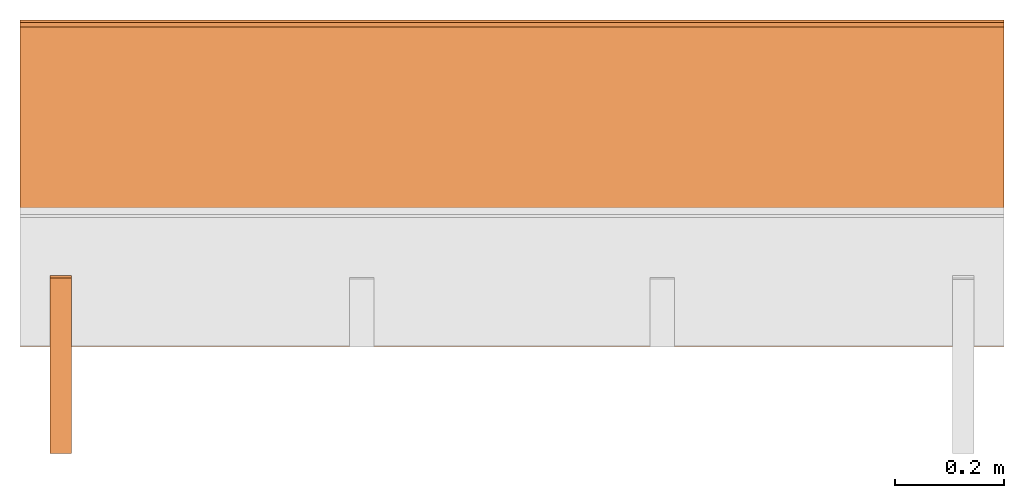
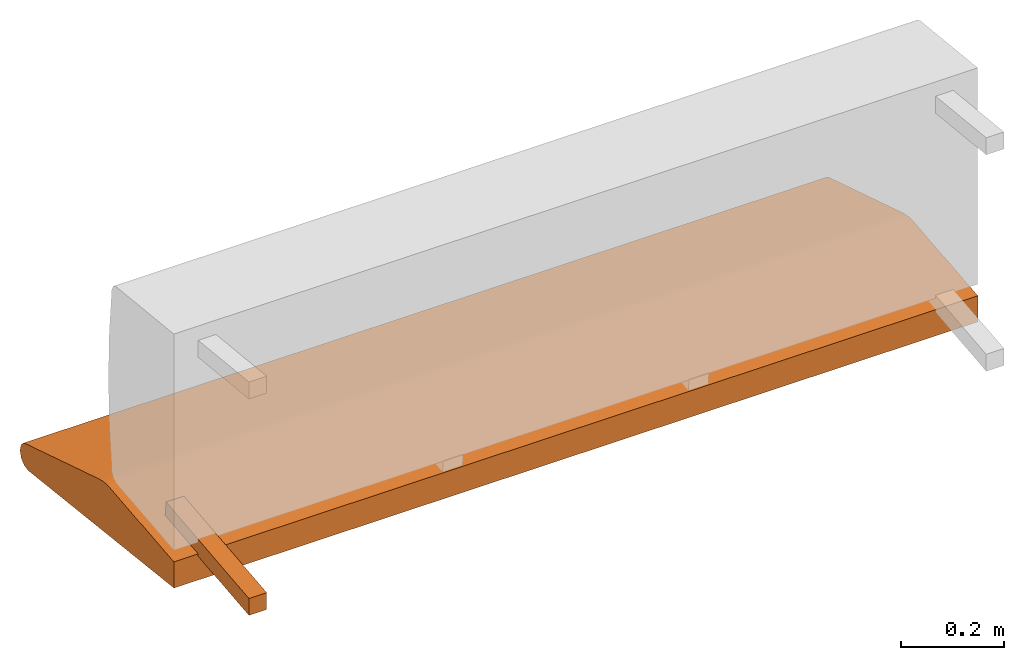
# One storey, part 2 of 3: 2 proxies, 1 element without a shape of its own.
"""IFC2X3 building model written with IfcOpenShell, lengths in metres."""

from ifc_helpers import new_model, si_unit, direction, origin_with_axes, place, context, project, spatial, faceted_brep, source, transform, mapped, element, aggregate, save


model = new_model("IFC2X3")

# Units and contexts
model_context = context("Model", 3, precision=1e-06, world=origin_with_axes(), true_north=direction((0.0, 1.0, 0.0)))
ifc_project = project(units=[si_unit("LENGTHUNIT", "METRE"), si_unit("AREAUNIT", "SQUARE_METRE"), si_unit("VOLUMEUNIT", "CUBIC_METRE")], contexts=[model_context])

# Site, building, storey
site_placement = place(None, origin_with_axes())
site = spatial("IfcSite", under=ifc_project, at=site_placement, CompositionType="ELEMENT")
building_placement = place(site_placement, origin_with_axes())
building = spatial("IfcBuilding", under=site, at=building_placement, Name="Default Building", CompositionType="ELEMENT")
storey_placement = place(building_placement, origin_with_axes())
storey = spatial("IfcBuildingStorey", under=building, at=storey_placement, Name="Default Storey", CompositionType="ELEMENT", Elevation=0.0)

# Assembly, proxies
assembly_placement = place(storey_placement, origin_with_axes())
assembly = element("IfcElementAssembly", 1, at=assembly_placement, inside=storey, AssemblyPlace="NOTDEFINED", PredefinedType="NOTDEFINED")
shared_shape_1 = source(origin_with_axes(), model_context, "Body", "Brep", [
    faceted_brep([(-0.8100000023841858, -0.3086628317832947, -0.31151315569877625), (-0.8100000023841858, -0.3086628317832947, -0.2712928354740143), (-0.8500000238418579, -0.3086628317832947, -0.31151315569877625), (-0.8500000238418579, -0.3086628317832947, -0.31151315569877625), (-0.8100000023841858, -0.3086628317832947, -0.2712928354740143), (-0.8500000238418579, -0.3086628317832947, -0.2712928354740143), (-0.8100000023841858, -0.3086628317832947, -0.2712928354740143), (-0.8100000023841858, 0.014455263502895832, -0.23733174800872803), (-0.8500000238418579, -0.3086628317832947, -0.2712928354740143), (-0.8500000238418579, -0.3086628317832947, -0.2712928354740143), (-0.8100000023841858, 0.014455263502895832, -0.23733174800872803), (-0.8500000238418579, 0.014455263502895832, -0.23733174800872803), (-0.8100000023841858, 0.014455263502895832, -0.23733174800872803), (-0.8100000023841858, 0.018636401742696762, -0.2771126329898834), (-0.8500000238418579, 0.014455263502895832, -0.23733174800872803), (-0.8500000238418579, 0.014455263502895832, -0.23733174800872803), (-0.8100000023841858, 0.018636401742696762, -0.2771126329898834), (-0.8500000238418579, 0.018636401742696762, -0.2771126329898834), (-0.8100000023841858, 0.018636401742696762, -0.2771126329898834), (-0.8100000023841858, -0.3086628317832947, -0.31151315569877625), (-0.8500000238418579, 0.018636401742696762, -0.2771126329898834), (-0.8500000238418579, 0.018636401742696762, -0.2771126329898834), (-0.8100000023841858, -0.3086628317832947, -0.31151315569877625), (-0.8500000238418579, -0.3086628317832947, -0.31151315569877625), (-0.8100000023841858, 0.018636401742696762, -0.2771126329898834), (-0.8100000023841858, 0.014455263502895832, -0.23733174800872803), (-0.8100000023841858, -0.3086628317832947, -0.31151315569877625), (-0.8100000023841858, -0.3086628317832947, -0.31151315569877625), (-0.8100000023841858, 0.014455263502895832, -0.23733174800872803), (-0.8100000023841858, -0.3086628317832947, -0.2712928354740143), (-0.8500000238418579, 0.014455263502895832, -0.23733174800872803), (-0.8500000238418579, 0.018636401742696762, -0.2771126329898834), (-0.8500000238418579, -0.3086628317832947, -0.2712928354740143), (-0.8500000238418579, -0.3086628317832947, -0.2712928354740143), (-0.8500000238418579, 0.018636401742696762, -0.2771126329898834), (-0.8500000238418579, -0.3086628317832947, -0.31151315569877625)], [[[0, 1, 2]], [[3, 4, 5]], [[6, 7, 8]], [[9, 10, 11]], [[12, 13, 14]], [[15, 16, 17]], [[18, 19, 20]], [[21, 22, 23]], [[24, 25, 26]], [[27, 28, 29]], [[30, 31, 32]], [[33, 34, 35]]]),
])
proxy_1_placement = place(assembly_placement, origin_with_axes())
proxy_1 = element("IfcBuildingElementProxy", 2, at=proxy_1_placement, Name="2", ObjectType="2", CompositionType="ELEMENT", context=model_context, shape_type="MappedRepresentation", body=[
    mapped(shared_shape_1, transform((0.0, 0.0, 0.0), scale=1.0)),
])
shared_shape_2 = source(origin_with_axes(), model_context, "Body", "Brep", [
    faceted_brep([(-0.9049999713897705, 0.14882974326610565, -0.2589503824710846), (-0.9049999713897705, 0.1383768916130066, -0.2594982087612152), (0.9049999713897705, 0.14882974326610565, -0.2589503824710846), (0.9049999713897705, 0.14882974326610565, -0.2589503824710846), (-0.9049999713897705, 0.1383768916130066, -0.2594982087612152), (0.9049999713897705, 0.1383768916130066, -0.2594982087612152), (0.9049999713897705, 0.01817154325544834, -0.2721322774887085), (0.9049999713897705, 0.1383768916130066, -0.2594982087612152), (-0.9049999713897705, 0.01817154325544834, -0.2721322774887085), (-0.9049999713897705, 0.01817154325544834, -0.2721322774887085), (0.9049999713897705, 0.1383768916130066, -0.2594982087612152), (-0.9049999713897705, 0.1383768916130066, -0.2594982087612152), (0.9049999713897705, 0.17872387170791626, -0.2635232210159302), (-0.9049999713897705, 0.17872387170791626, -0.2635232210159302), (-0.9049999713897705, 0.16395066678524017, -0.26010021567344666), (0.9049999713897705, 0.17872387170791626, -0.2635232210159302), (-0.9049999713897705, 0.16395066678524017, -0.26010021567344666), (0.9049999713897705, 0.16395066678524017, -0.26010021567344666), (0.9049999713897705, 0.16395066678524017, -0.26010021567344666), (-0.9049999713897705, 0.16395066678524017, -0.26010021567344666), (-0.9049999713897705, 0.14882974326610565, -0.2589503824710846), (0.9049999713897705, 0.16395066678524017, -0.26010021567344666), (-0.9049999713897705, 0.14882974326610565, -0.2589503824710846), (0.9049999713897705, 0.14882974326610565, -0.2589503824710846), (0.9049999713897705, 0.17872387170791626, -0.2635232210159302), (0.9049999713897705, 0.4682733118534088, -0.3542293608188629), (-0.9049999713897705, 0.17872387170791626, -0.2635232210159302), (-0.9049999713897705, 0.17872387170791626, -0.2635232210159302), (0.9049999713897705, 0.4682733118534088, -0.3542293608188629), (-0.9049999713897705, 0.4682733118534088, -0.3542293608188629), (0.9049999713897705, 0.4682733118534088, -0.3542293608188629), (0.9049999713897705, 0.4762941300868988, -0.35816407203674316), (-0.9049999713897705, 0.4682733118534088, -0.3542293608188629), (-0.9049999713897705, 0.4682733118534088, -0.3542293608188629), (0.9049999713897705, 0.4762941300868988, -0.35816407203674316), (-0.9049999713897705, 0.4762941300868988, -0.35816407203674316), (0.9049999713897705, 0.4762941300868988, -0.35816407203674316), (0.9049999713897705, 0.4814260005950928, -0.36358925700187683), (-0.9049999713897705, 0.4762941300868988, -0.35816407203674316), (-0.9049999713897705, 0.4762941300868988, -0.35816407203674316), (0.9049999713897705, 0.4814260005950928, -0.36358925700187683), (-0.9049999713897705, 0.4814260005950928, -0.36358925700187683), (0.9049999713897705, 0.4814260005950928, -0.36358925700187683), (0.9049999713897705, 0.4845067262649536, -0.3668460547924042), (-0.9049999713897705, 0.4814260005950928, -0.36358925700187683), (-0.9049999713897705, 0.4814260005950928, -0.36358925700187683), (0.9049999713897705, 0.4845067262649536, -0.3668460547924042), (-0.9049999713897705, 0.4845067262649536, -0.3668460547924042), (0.9049999713897705, 0.4845067262649536, -0.3668460547924042), (0.9049999713897705, 0.48888999223709106, -0.3822925090789795), (-0.9049999713897705, 0.4845067262649536, -0.3668460547924042), (-0.9049999713897705, 0.4845067262649536, -0.3668460547924042), (0.9049999713897705, 0.48888999223709106, -0.3822925090789795), (-0.9049999713897705, 0.48888999223709106, -0.3822925090789795), (0.9049999713897705, 0.48888999223709106, -0.3822925090789795), (0.9049999713897705, 0.4845067262649536, -0.3977389633655548), (-0.9049999713897705, 0.48888999223709106, -0.3822925090789795), (-0.9049999713897705, 0.48888999223709106, -0.3822925090789795), (0.9049999713897705, 0.4845067262649536, -0.3977389633655548), (-0.9049999713897705, 0.4845067262649536, -0.3977389633655548), (0.9049999713897705, 0.4845067262649536, -0.3977389633655548), (0.9049999713897705, 0.4726635813713074, -0.40858080983161926), (-0.9049999713897705, 0.4845067262649536, -0.3977389633655548), (-0.9049999713897705, 0.4845067262649536, -0.3977389633655548), (0.9049999713897705, 0.4726635813713074, -0.40858080983161926), (-0.9049999713897705, 0.4726635813713074, -0.40858080983161926), (0.9049999713897705, 0.4726635813713074, -0.40858080983161926), (0.9049999713897705, 0.4568909704685211, -0.41158604621887207), (-0.9049999713897705, 0.4726635813713074, -0.40858080983161926), (-0.9049999713897705, 0.4726635813713074, -0.40858080983161926), (0.9049999713897705, 0.4568909704685211, -0.41158604621887207), (-0.9049999713897705, 0.4568909704685211, -0.41158604621887207), (0.9049999713897705, 0.4568909704685211, -0.41158604621887207), (0.9049999713897705, 0.4574563503265381, -0.4066162109375), (-0.9049999713897705, 0.4568909704685211, -0.41158604621887207), (-0.9049999713897705, 0.4568909704685211, -0.41158604621887207), (0.9049999713897705, 0.4574563503265381, -0.4066162109375), (-0.9049999713897705, 0.4574563503265381, -0.4066162109375), (0.9049999713897705, 0.4574563503265381, -0.4066162109375), (0.9049999713897705, 0.45688581466674805, -0.41162365674972534), (-0.9049999713897705, 0.4574563503265381, -0.4066162109375), (-0.9049999713897705, 0.4574563503265381, -0.4066162109375), (0.9049999713897705, 0.45688581466674805, -0.41162365674972534), (-0.9049999713897705, 0.45688581466674805, -0.41162365674972534), (0.9049999713897705, 0.45688581466674805, -0.41162365674972534), (0.9049999713897705, -0.11158759891986847, -0.3467162549495697), (-0.9049999713897705, 0.45688581466674805, -0.41162365674972534), (-0.9049999713897705, 0.45688581466674805, -0.41162365674972534), (0.9049999713897705, -0.11158759891986847, -0.3467162549495697), (-0.9049999713897705, -0.11158759891986847, -0.3467162549495697), (0.9049999713897705, -0.11158759891986847, -0.3467162549495697), (0.9049999713897705, -0.111614890396595, -0.34647175669670105), (-0.9049999713897705, -0.11158759891986847, -0.3467162549495697), (-0.9049999713897705, -0.11158759891986847, -0.3467162549495697), (0.9049999713897705, -0.111614890396595, -0.34647175669670105), (-0.9049999713897705, -0.111614890396595, -0.34647175669670105), (0.9049999713897705, -0.111614890396595, -0.34647175669670105), (0.9049999713897705, -0.11162230372428894, -0.3463222086429596), (-0.9049999713897705, -0.111614890396595, -0.34647175669670105), (-0.9049999713897705, -0.111614890396595, -0.34647175669670105), (0.9049999713897705, -0.11162230372428894, -0.3463222086429596), (-0.9049999713897705, -0.11162230372428894, -0.3463222086429596), (0.9049999713897705, -0.11162230372428894, -0.3463222086429596), (0.9049999713897705, -0.11162848770618439, -0.3461674153804779), (-0.9049999713897705, -0.11162230372428894, -0.3463222086429596), (-0.9049999713897705, -0.11162230372428894, -0.3463222086429596), (0.9049999713897705, -0.11162848770618439, -0.3461674153804779), (-0.9049999713897705, -0.11162848770618439, -0.3461674153804779), (0.9049999713897705, -0.11162848770618439, -0.3461674153804779), (0.9049999713897705, -0.11163215339183807, -0.3459841310977936), (-0.9049999713897705, -0.11162848770618439, -0.3461674153804779), (-0.9049999713897705, -0.11162848770618439, -0.3461674153804779), (0.9049999713897705, -0.11163215339183807, -0.3459841310977936), (-0.9049999713897705, -0.11163215339183807, -0.3459841310977936), (0.9049999713897705, -0.11163215339183807, -0.3459841310977936), (0.9049999713897705, -0.11163294315338135, -0.3458006978034973), (-0.9049999713897705, -0.11163215339183807, -0.3459841310977936), (-0.9049999713897705, -0.11163215339183807, -0.3459841310977936), (0.9049999713897705, -0.11163294315338135, -0.3458006978034973), (-0.9049999713897705, -0.11163294315338135, -0.3458006978034973), (0.9049999713897705, -0.11163294315338135, -0.3458006978034973), (0.9049999713897705, -0.11163128912448883, -0.34556692838668823), (-0.9049999713897705, -0.11163294315338135, -0.3458006978034973), (-0.9049999713897705, -0.11163294315338135, -0.3458006978034973), (0.9049999713897705, -0.11163128912448883, -0.34556692838668823), (-0.9049999713897705, -0.11163128912448883, -0.34556692838668823), (0.9049999713897705, -0.11163128912448883, -0.34556692838668823), (0.9049999713897705, -0.11162881553173065, -0.3453170657157898), (-0.9049999713897705, -0.11163128912448883, -0.34556692838668823), (-0.9049999713897705, -0.11163128912448883, -0.34556692838668823), (0.9049999713897705, -0.11162881553173065, -0.3453170657157898), (-0.9049999713897705, -0.11162881553173065, -0.3453170657157898), (0.9049999713897705, -0.11162881553173065, -0.3453170657157898), (0.9049999713897705, -0.11162382364273071, -0.34508395195007324), (-0.9049999713897705, -0.11162881553173065, -0.3453170657157898), (-0.9049999713897705, -0.11162881553173065, -0.3453170657157898), (0.9049999713897705, -0.11162382364273071, -0.34508395195007324), (-0.9049999713897705, -0.11162382364273071, -0.34508395195007324), (0.9049999713897705, -0.11162382364273071, -0.34508395195007324), (0.9049999713897705, -0.11161737889051437, -0.34479713439941406), (-0.9049999713897705, -0.11162382364273071, -0.34508395195007324), (-0.9049999713897705, -0.11162382364273071, -0.34508395195007324), (0.9049999713897705, -0.11161737889051437, -0.34479713439941406), (-0.9049999713897705, -0.11161737889051437, -0.34479713439941406), (0.9049999713897705, -0.11161737889051437, -0.34479713439941406), (0.9049999713897705, -0.11161097884178162, -0.3445703685283661), (-0.9049999713897705, -0.11161737889051437, -0.34479713439941406), (-0.9049999713897705, -0.11161737889051437, -0.34479713439941406), (0.9049999713897705, -0.11161097884178162, -0.3445703685283661), (-0.9049999713897705, -0.11161097884178162, -0.3445703685283661), (0.9049999713897705, -0.11161097884178162, -0.3445703685283661), (0.9049999713897705, -0.11160170286893845, -0.34428343176841736), (-0.9049999713897705, -0.11161097884178162, -0.3445703685283661), (-0.9049999713897705, -0.11161097884178162, -0.3445703685283661), (0.9049999713897705, -0.11160170286893845, -0.34428343176841736), (-0.9049999713897705, -0.11160170286893845, -0.34428343176841736), (0.9049999713897705, -0.11160170286893845, -0.34428343176841736), (0.9049999713897705, -0.11158967018127441, -0.3439476490020752), (-0.9049999713897705, -0.11160170286893845, -0.34428343176841736), (-0.9049999713897705, -0.11160170286893845, -0.34428343176841736), (0.9049999713897705, -0.11158967018127441, -0.3439476490020752), (-0.9049999713897705, -0.11158967018127441, -0.3439476490020752), (0.9049999713897705, -0.11158967018127441, -0.3439476490020752), (0.9049999713897705, -0.11157859116792679, -0.34364718198776245), (-0.9049999713897705, -0.11158967018127441, -0.3439476490020752), (-0.9049999713897705, -0.11158967018127441, -0.3439476490020752), (0.9049999713897705, -0.11157859116792679, -0.34364718198776245), (-0.9049999713897705, -0.11157859116792679, -0.34364718198776245), (0.9049999713897705, -0.11157859116792679, -0.34364718198776245), (0.9049999713897705, -0.1115475445985794, -0.3428836464881897), (-0.9049999713897705, -0.11157859116792679, -0.34364718198776245), (-0.9049999713897705, -0.11157859116792679, -0.34364718198776245), (0.9049999713897705, -0.1115475445985794, -0.3428836464881897), (-0.9049999713897705, -0.1115475445985794, -0.3428836464881897), (0.9049999713897705, -0.1115475445985794, -0.3428836464881897), (0.9049999713897705, -0.11152128130197525, -0.3422744572162628), (-0.9049999713897705, -0.1115475445985794, -0.3428836464881897), (-0.9049999713897705, -0.1115475445985794, -0.3428836464881897), (0.9049999713897705, -0.11152128130197525, -0.3422744572162628), (-0.9049999713897705, -0.11152128130197525, -0.3422744572162628), (0.9049999713897705, -0.11152128130197525, -0.3422744572162628), (0.9049999713897705, -0.11149738729000092, -0.34173157811164856), (-0.9049999713897705, -0.11152128130197525, -0.3422744572162628), (-0.9049999713897705, -0.11152128130197525, -0.3422744572162628), (0.9049999713897705, -0.11149738729000092, -0.34173157811164856), (-0.9049999713897705, -0.11149738729000092, -0.34173157811164856), (0.9049999713897705, -0.11149738729000092, -0.34173157811164856), (0.9049999713897705, -0.11122065782546997, -0.28472810983657837), (-0.9049999713897705, -0.11149738729000092, -0.34173157811164856), (-0.9049999713897705, -0.11149738729000092, -0.34173157811164856), (0.9049999713897705, -0.11122065782546997, -0.28472810983657837), (-0.9049999713897705, -0.11122065782546997, -0.28472810983657837), (0.9049999713897705, -0.11122065782546997, -0.28472810983657837), (0.9049999713897705, 0.01806718483567238, -0.27113938331604004), (-0.9049999713897705, -0.11122065782546997, -0.28472810983657837), (-0.9049999713897705, -0.11122065782546997, -0.28472810983657837), (0.9049999713897705, 0.01806718483567238, -0.27113938331604004), (-0.9049999713897705, 0.01806718483567238, -0.27113938331604004), (0.9049999713897705, 0.01806718483567238, -0.27113938331604004), (0.9049999713897705, 0.01817154325544834, -0.2721322774887085), (-0.9049999713897705, 0.01806718483567238, -0.27113938331604004), (-0.9049999713897705, 0.01806718483567238, -0.27113938331604004), (0.9049999713897705, 0.01817154325544834, -0.2721322774887085), (-0.9049999713897705, 0.01817154325544834, -0.2721322774887085), (0.9049999713897705, 0.4814260005950928, -0.36358925700187683), (0.9049999713897705, 0.4762941300868988, -0.35816407203674316), (0.9049999713897705, 0.4682733118534088, -0.3542293608188629), (0.9049999713897705, 0.4574563503265381, -0.4066162109375), (0.9049999713897705, 0.4568909704685211, -0.41158604621887207), (0.9049999713897705, 0.4726635813713074, -0.40858080983161926), (0.9049999713897705, -0.11158759891986847, -0.3467162549495697), (0.9049999713897705, 0.45688581466674805, -0.41162365674972534), (0.9049999713897705, 0.4574563503265381, -0.4066162109375), (0.9049999713897705, 0.4845067262649536, -0.3668460547924042), (0.9049999713897705, 0.4814260005950928, -0.36358925700187683), (0.9049999713897705, 0.4574563503265381, -0.4066162109375), (0.9049999713897705, 0.01806718483567238, -0.27113938331604004), (0.9049999713897705, -0.11122065782546997, -0.28472810983657837), (0.9049999713897705, 0.01817154325544834, -0.2721322774887085), (0.9049999713897705, 0.01817154325544834, -0.2721322774887085), (0.9049999713897705, -0.11122065782546997, -0.28472810983657837), (0.9049999713897705, -0.11149738729000092, -0.34173157811164856), (0.9049999713897705, 0.16395066678524017, -0.26010021567344666), (0.9049999713897705, 0.14882974326610565, -0.2589503824710846), (0.9049999713897705, 0.4574563503265381, -0.4066162109375), (0.9049999713897705, 0.4574563503265381, -0.4066162109375), (0.9049999713897705, 0.14882974326610565, -0.2589503824710846), (0.9049999713897705, 0.1383768916130066, -0.2594982087612152), (0.9049999713897705, 0.4574563503265381, -0.4066162109375), (0.9049999713897705, 0.1383768916130066, -0.2594982087612152), (0.9049999713897705, -0.11158759891986847, -0.3467162549495697), (0.9049999713897705, -0.11158759891986847, -0.3467162549495697), (0.9049999713897705, 0.1383768916130066, -0.2594982087612152), (0.9049999713897705, 0.01817154325544834, -0.2721322774887085), (0.9049999713897705, -0.11158759891986847, -0.3467162549495697), (0.9049999713897705, 0.01817154325544834, -0.2721322774887085), (0.9049999713897705, -0.111614890396595, -0.34647175669670105), (0.9049999713897705, 0.4726635813713074, -0.40858080983161926), (0.9049999713897705, 0.4845067262649536, -0.3977389633655548), (0.9049999713897705, 0.4574563503265381, -0.4066162109375), (0.9049999713897705, 0.4574563503265381, -0.4066162109375), (0.9049999713897705, 0.4845067262649536, -0.3977389633655548), (0.9049999713897705, 0.48888999223709106, -0.3822925090789795), (0.9049999713897705, 0.4574563503265381, -0.4066162109375), (0.9049999713897705, 0.48888999223709106, -0.3822925090789795), (0.9049999713897705, 0.4845067262649536, -0.3668460547924042), (0.9049999713897705, 0.4814260005950928, -0.36358925700187683), (0.9049999713897705, 0.4682733118534088, -0.3542293608188629), (0.9049999713897705, 0.4574563503265381, -0.4066162109375), (0.9049999713897705, 0.4574563503265381, -0.4066162109375), (0.9049999713897705, 0.4682733118534088, -0.3542293608188629), (0.9049999713897705, 0.17872387170791626, -0.2635232210159302), (0.9049999713897705, 0.4574563503265381, -0.4066162109375), (0.9049999713897705, 0.17872387170791626, -0.2635232210159302), (0.9049999713897705, 0.16395066678524017, -0.26010021567344666), (0.9049999713897705, -0.11149738729000092, -0.34173157811164856), (0.9049999713897705, -0.11152128130197525, -0.3422744572162628), (0.9049999713897705, 0.01817154325544834, -0.2721322774887085), (0.9049999713897705, 0.01817154325544834, -0.2721322774887085), (0.9049999713897705, -0.11152128130197525, -0.3422744572162628), (0.9049999713897705, -0.1115475445985794, -0.3428836464881897), (0.9049999713897705, 0.01817154325544834, -0.2721322774887085), (0.9049999713897705, -0.1115475445985794, -0.3428836464881897), (0.9049999713897705, -0.11157859116792679, -0.34364718198776245), (0.9049999713897705, -0.11157859116792679, -0.34364718198776245), (0.9049999713897705, -0.11158967018127441, -0.3439476490020752), (0.9049999713897705, 0.01817154325544834, -0.2721322774887085), (0.9049999713897705, 0.01817154325544834, -0.2721322774887085), (0.9049999713897705, -0.11158967018127441, -0.3439476490020752), (0.9049999713897705, -0.11160170286893845, -0.34428343176841736), (0.9049999713897705, 0.01817154325544834, -0.2721322774887085), (0.9049999713897705, -0.11160170286893845, -0.34428343176841736), (0.9049999713897705, -0.11161097884178162, -0.3445703685283661), (0.9049999713897705, -0.11161097884178162, -0.3445703685283661), (0.9049999713897705, -0.11161737889051437, -0.34479713439941406), (0.9049999713897705, 0.01817154325544834, -0.2721322774887085), (0.9049999713897705, 0.01817154325544834, -0.2721322774887085), (0.9049999713897705, -0.11161737889051437, -0.34479713439941406), (0.9049999713897705, -0.11162382364273071, -0.34508395195007324), (0.9049999713897705, 0.01817154325544834, -0.2721322774887085), (0.9049999713897705, -0.11162382364273071, -0.34508395195007324), (0.9049999713897705, -0.11162881553173065, -0.3453170657157898), (0.9049999713897705, -0.11162881553173065, -0.3453170657157898), (0.9049999713897705, -0.11163128912448883, -0.34556692838668823), (0.9049999713897705, 0.01817154325544834, -0.2721322774887085), (0.9049999713897705, 0.01817154325544834, -0.2721322774887085), (0.9049999713897705, -0.11163128912448883, -0.34556692838668823), (0.9049999713897705, -0.11163294315338135, -0.3458006978034973), (0.9049999713897705, 0.01817154325544834, -0.2721322774887085), (0.9049999713897705, -0.11163294315338135, -0.3458006978034973), (0.9049999713897705, -0.11163215339183807, -0.3459841310977936), (0.9049999713897705, -0.11163215339183807, -0.3459841310977936), (0.9049999713897705, -0.11162848770618439, -0.3461674153804779), (0.9049999713897705, 0.01817154325544834, -0.2721322774887085), (0.9049999713897705, 0.01817154325544834, -0.2721322774887085), (0.9049999713897705, -0.11162848770618439, -0.3461674153804779), (0.9049999713897705, -0.11162230372428894, -0.3463222086429596), (0.9049999713897705, 0.01817154325544834, -0.2721322774887085), (0.9049999713897705, -0.11162230372428894, -0.3463222086429596), (0.9049999713897705, -0.111614890396595, -0.34647175669670105), (-0.9049999713897705, 0.4574563503265381, -0.4066162109375), (-0.9049999713897705, 0.45688581466674805, -0.41162365674972534), (-0.9049999713897705, -0.11158759891986847, -0.3467162549495697), (-0.9049999713897705, 0.4682733118534088, -0.3542293608188629), (-0.9049999713897705, 0.4762941300868988, -0.35816407203674316), (-0.9049999713897705, 0.4574563503265381, -0.4066162109375), (-0.9049999713897705, 0.4574563503265381, -0.4066162109375), (-0.9049999713897705, 0.4762941300868988, -0.35816407203674316), (-0.9049999713897705, 0.4814260005950928, -0.36358925700187683), (-0.9049999713897705, 0.4726635813713074, -0.40858080983161926), (-0.9049999713897705, 0.4568909704685211, -0.41158604621887207), (-0.9049999713897705, 0.4574563503265381, -0.4066162109375), (-0.9049999713897705, -0.11122065782546997, -0.28472810983657837), (-0.9049999713897705, 0.01806718483567238, -0.27113938331604004), (-0.9049999713897705, -0.11149738729000092, -0.34173157811164856), (-0.9049999713897705, -0.11149738729000092, -0.34173157811164856), (-0.9049999713897705, 0.01806718483567238, -0.27113938331604004), (-0.9049999713897705, 0.01817154325544834, -0.2721322774887085), (-0.9049999713897705, -0.11149738729000092, -0.34173157811164856), (-0.9049999713897705, 0.01817154325544834, -0.2721322774887085), (-0.9049999713897705, -0.11152128130197525, -0.3422744572162628), (-0.9049999713897705, -0.11160170286893845, -0.34428343176841736), (-0.9049999713897705, -0.11158967018127441, -0.3439476490020752), (-0.9049999713897705, 0.01817154325544834, -0.2721322774887085), (-0.9049999713897705, 0.4845067262649536, -0.3977389633655548), (-0.9049999713897705, 0.4726635813713074, -0.40858080983161926), (-0.9049999713897705, 0.48888999223709106, -0.3822925090789795), (-0.9049999713897705, 0.48888999223709106, -0.3822925090789795), (-0.9049999713897705, 0.4726635813713074, -0.40858080983161926), (-0.9049999713897705, 0.4574563503265381, -0.4066162109375), (-0.9049999713897705, 0.48888999223709106, -0.3822925090789795), (-0.9049999713897705, 0.4574563503265381, -0.4066162109375), (-0.9049999713897705, 0.4845067262649536, -0.3668460547924042), (-0.9049999713897705, 0.4845067262649536, -0.3668460547924042), (-0.9049999713897705, 0.4574563503265381, -0.4066162109375), (-0.9049999713897705, 0.4814260005950928, -0.36358925700187683), (-0.9049999713897705, 0.01817154325544834, -0.2721322774887085), (-0.9049999713897705, 0.1383768916130066, -0.2594982087612152), (-0.9049999713897705, 0.4574563503265381, -0.4066162109375), (-0.9049999713897705, 0.4574563503265381, -0.4066162109375), (-0.9049999713897705, 0.1383768916130066, -0.2594982087612152), (-0.9049999713897705, 0.14882974326610565, -0.2589503824710846), (-0.9049999713897705, -0.11158967018127441, -0.3439476490020752), (-0.9049999713897705, -0.11157859116792679, -0.34364718198776245), (-0.9049999713897705, 0.01817154325544834, -0.2721322774887085), (-0.9049999713897705, 0.01817154325544834, -0.2721322774887085), (-0.9049999713897705, -0.11157859116792679, -0.34364718198776245), (-0.9049999713897705, -0.1115475445985794, -0.3428836464881897), (-0.9049999713897705, 0.01817154325544834, -0.2721322774887085), (-0.9049999713897705, -0.1115475445985794, -0.3428836464881897), (-0.9049999713897705, -0.11152128130197525, -0.3422744572162628), (-0.9049999713897705, 0.14882974326610565, -0.2589503824710846), (-0.9049999713897705, 0.16395066678524017, -0.26010021567344666), (-0.9049999713897705, 0.4574563503265381, -0.4066162109375), (-0.9049999713897705, 0.4574563503265381, -0.4066162109375), (-0.9049999713897705, 0.16395066678524017, -0.26010021567344666), (-0.9049999713897705, 0.17872387170791626, -0.2635232210159302), (-0.9049999713897705, 0.4574563503265381, -0.4066162109375), (-0.9049999713897705, 0.17872387170791626, -0.2635232210159302), (-0.9049999713897705, 0.4682733118534088, -0.3542293608188629), (-0.9049999713897705, -0.11163294315338135, -0.3458006978034973), (-0.9049999713897705, -0.11163128912448883, -0.34556692838668823), (-0.9049999713897705, 0.01817154325544834, -0.2721322774887085), (-0.9049999713897705, 0.01817154325544834, -0.2721322774887085), (-0.9049999713897705, -0.11163128912448883, -0.34556692838668823), (-0.9049999713897705, -0.11162881553173065, -0.3453170657157898), (-0.9049999713897705, 0.01817154325544834, -0.2721322774887085), (-0.9049999713897705, -0.11162881553173065, -0.3453170657157898), (-0.9049999713897705, -0.11162382364273071, -0.34508395195007324), (-0.9049999713897705, 0.4574563503265381, -0.4066162109375), (-0.9049999713897705, -0.11158759891986847, -0.3467162549495697), (-0.9049999713897705, 0.01817154325544834, -0.2721322774887085), (-0.9049999713897705, 0.01817154325544834, -0.2721322774887085), (-0.9049999713897705, -0.11158759891986847, -0.3467162549495697), (-0.9049999713897705, -0.111614890396595, -0.34647175669670105), (-0.9049999713897705, 0.01817154325544834, -0.2721322774887085), (-0.9049999713897705, -0.111614890396595, -0.34647175669670105), (-0.9049999713897705, -0.11162230372428894, -0.3463222086429596), (-0.9049999713897705, -0.11162382364273071, -0.34508395195007324), (-0.9049999713897705, -0.11161737889051437, -0.34479713439941406), (-0.9049999713897705, 0.01817154325544834, -0.2721322774887085), (-0.9049999713897705, 0.01817154325544834, -0.2721322774887085), (-0.9049999713897705, -0.11161737889051437, -0.34479713439941406), (-0.9049999713897705, -0.11161097884178162, -0.3445703685283661), (-0.9049999713897705, 0.01817154325544834, -0.2721322774887085), (-0.9049999713897705, -0.11161097884178162, -0.3445703685283661), (-0.9049999713897705, -0.11160170286893845, -0.34428343176841736), (-0.9049999713897705, -0.11162230372428894, -0.3463222086429596), (-0.9049999713897705, -0.11162848770618439, -0.3461674153804779), (-0.9049999713897705, 0.01817154325544834, -0.2721322774887085), (-0.9049999713897705, 0.01817154325544834, -0.2721322774887085), (-0.9049999713897705, -0.11162848770618439, -0.3461674153804779), (-0.9049999713897705, -0.11163215339183807, -0.3459841310977936), (-0.9049999713897705, 0.01817154325544834, -0.2721322774887085), (-0.9049999713897705, -0.11163215339183807, -0.3459841310977936), (-0.9049999713897705, -0.11163294315338135, -0.3458006978034973)], [[[0, 1, 2]], [[3, 4, 5]], [[6, 7, 8]], [[9, 10, 11]], [[12, 13, 14]], [[15, 16, 17]], [[18, 19, 20]], [[21, 22, 23]], [[24, 25, 26]], [[27, 28, 29]], [[30, 31, 32]], [[33, 34, 35]], [[36, 37, 38]], [[39, 40, 41]], [[42, 43, 44]], [[45, 46, 47]], [[48, 49, 50]], [[51, 52, 53]], [[54, 55, 56]], [[57, 58, 59]], [[60, 61, 62]], [[63, 64, 65]], [[66, 67, 68]], [[69, 70, 71]], [[72, 73, 74]], [[75, 76, 77]], [[78, 79, 80]], [[81, 82, 83]], [[84, 85, 86]], [[87, 88, 89]], [[90, 91, 92]], [[93, 94, 95]], [[96, 97, 98]], [[99, 100, 101]], [[102, 103, 104]], [[105, 106, 107]], [[108, 109, 110]], [[111, 112, 113]], [[114, 115, 116]], [[117, 118, 119]], [[120, 121, 122]], [[123, 124, 125]], [[126, 127, 128]], [[129, 130, 131]], [[132, 133, 134]], [[135, 136, 137]], [[138, 139, 140]], [[141, 142, 143]], [[144, 145, 146]], [[147, 148, 149]], [[150, 151, 152]], [[153, 154, 155]], [[156, 157, 158]], [[159, 160, 161]], [[162, 163, 164]], [[165, 166, 167]], [[168, 169, 170]], [[171, 172, 173]], [[174, 175, 176]], [[177, 178, 179]], [[180, 181, 182]], [[183, 184, 185]], [[186, 187, 188]], [[189, 190, 191]], [[192, 193, 194]], [[195, 196, 197]], [[198, 199, 200]], [[201, 202, 203]], [[204, 205, 206]], [[207, 208, 209]], [[210, 211, 212]], [[213, 214, 215]], [[216, 217, 218]], [[219, 220, 221]], [[222, 223, 224]], [[225, 226, 227]], [[228, 229, 230]], [[231, 232, 233]], [[234, 235, 236]], [[237, 238, 239]], [[240, 241, 242]], [[243, 244, 245]], [[246, 247, 248]], [[249, 250, 251]], [[252, 253, 254]], [[255, 256, 257]], [[258, 259, 260]], [[261, 262, 263]], [[264, 265, 266]], [[267, 268, 269]], [[270, 271, 272]], [[273, 274, 275]], [[276, 277, 278]], [[279, 280, 281]], [[282, 283, 284]], [[285, 286, 287]], [[288, 289, 290]], [[291, 292, 293]], [[294, 295, 296]], [[297, 298, 299]], [[300, 301, 302]], [[303, 304, 305]], [[306, 307, 308]], [[309, 310, 311]], [[312, 313, 314]], [[315, 316, 317]], [[318, 319, 320]], [[321, 322, 323]], [[324, 325, 326]], [[327, 328, 329]], [[330, 331, 332]], [[333, 334, 335]], [[336, 337, 338]], [[339, 340, 341]], [[342, 343, 344]], [[345, 346, 347]], [[348, 349, 350]], [[351, 352, 353]], [[354, 355, 356]], [[357, 358, 359]], [[360, 361, 362]], [[363, 364, 365]], [[366, 367, 368]], [[369, 370, 371]], [[372, 373, 374]], [[375, 376, 377]], [[378, 379, 380]], [[381, 382, 383]], [[384, 385, 386]], [[387, 388, 389]], [[390, 391, 392]], [[393, 394, 395]]]),
])
proxy_2_placement = place(assembly_placement, origin_with_axes())
proxy_2 = element("IfcBuildingElementProxy", 3, at=proxy_2_placement, Name="6", ObjectType="6", CompositionType="ELEMENT", context=model_context, shape_type="MappedRepresentation", body=[
    mapped(shared_shape_2, transform((0.0, 0.0, 0.0), scale=1.0)),
])
aggregate(assembly, [proxy_1, proxy_2])

save(model, "model.ifc")
